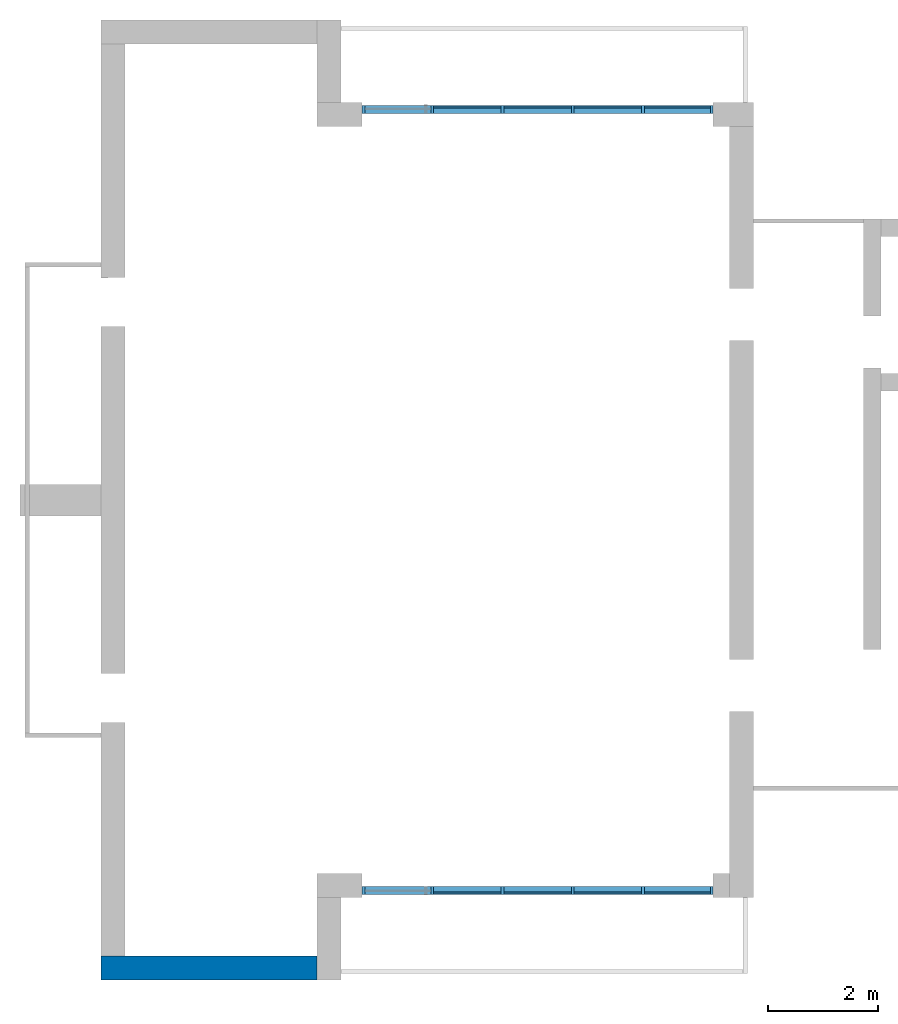
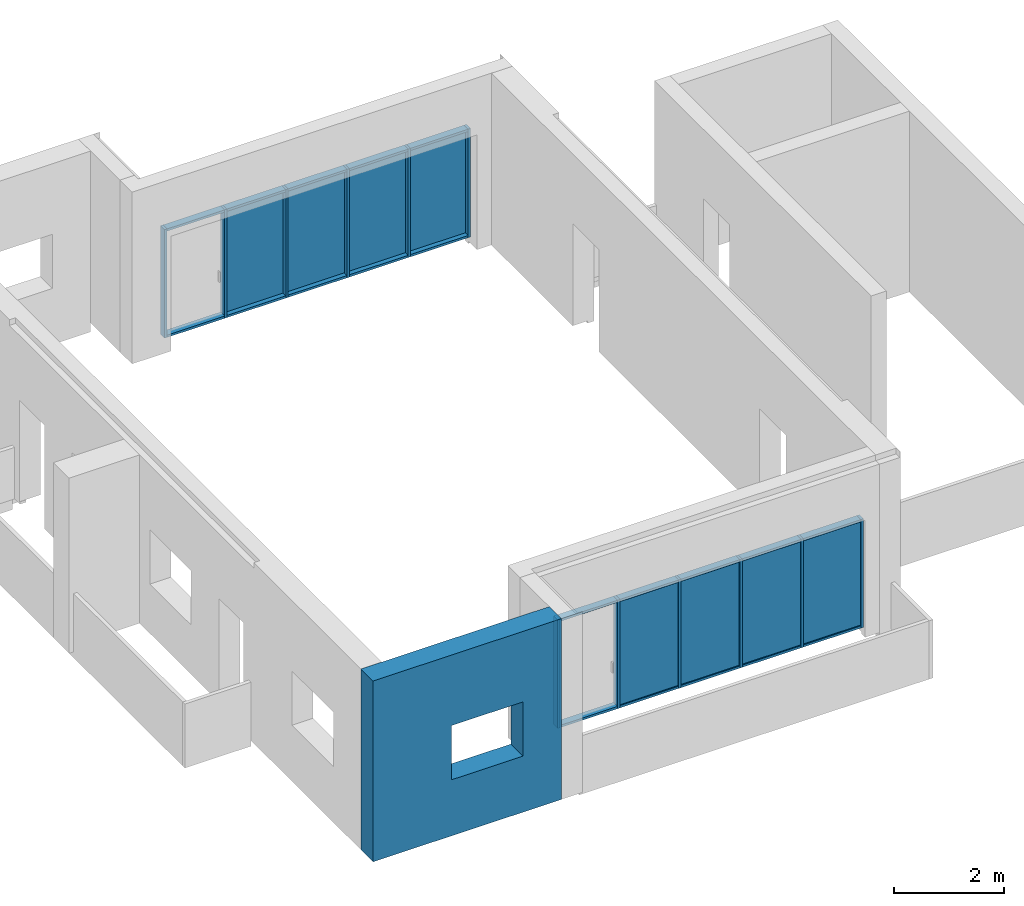
# One storey, part 1 of 4: 32 members, 8 plates, 1 wall, 1 opening, 2 elements without a shape of their own.
"""IFC2X3 building model written with IfcOpenShell, lengths in millimetres."""

from ifc_helpers import new_model, entity, si_unit, converted_unit, derived_unit, direction, frame, frame_2d, origin, origin_2d_with_axis, place, context, subcontext, project, spatial, rectangle, extrude, source, transform, mapped, material, layer, layer_set, layer_usage, type_object, type_shapes, element, aggregate, save


model = new_model("IFC2X3")

# Units and contexts
model_context = context("Model", 3, precision=0.01, world=origin(), true_north=direction((6.12303176911189e-17, 1.0)))
body_context = subcontext(model_context, "Body", "Model", "MODEL_VIEW")
ifc_project = project(units=[si_unit("LENGTHUNIT", "METRE", prefix="MILLI"), si_unit("AREAUNIT", "SQUARE_METRE"), si_unit("VOLUMEUNIT", "CUBIC_METRE"), converted_unit("PLANEANGLEUNIT", "DEGREE", entity("IfcRatioMeasure", 0.0174532925199433), si_unit("PLANEANGLEUNIT", "RADIAN"), dimensions=[0, 0, 0, 0, 0, 0, 0]), si_unit("MASSUNIT", "GRAM", prefix="KILO"), derived_unit("MASSDENSITYUNIT", [(si_unit("MASSUNIT", "GRAM", prefix="KILO"), 1), (si_unit("LENGTHUNIT", "METRE"), -3)]), si_unit("TIMEUNIT", "SECOND"), si_unit("FREQUENCYUNIT", "HERTZ"), si_unit("THERMODYNAMICTEMPERATUREUNIT", "DEGREE_CELSIUS"), derived_unit("THERMALTRANSMITTANCEUNIT", [(si_unit("MASSUNIT", "GRAM", prefix="KILO"), 1), (si_unit("THERMODYNAMICTEMPERATUREUNIT", "KELVIN"), -1), (si_unit("TIMEUNIT", "SECOND"), -3)]), derived_unit("VOLUMETRICFLOWRATEUNIT", [(si_unit("LENGTHUNIT", "METRE"), 3), (si_unit("TIMEUNIT", "SECOND"), -1)]), si_unit("ELECTRICCURRENTUNIT", "AMPERE"), si_unit("ELECTRICVOLTAGEUNIT", "VOLT"), si_unit("POWERUNIT", "WATT"), si_unit("FORCEUNIT", "NEWTON", prefix="KILO"), si_unit("ILLUMINANCEUNIT", "LUX"), si_unit("LUMINOUSFLUXUNIT", "LUMEN"), si_unit("LUMINOUSINTENSITYUNIT", "CANDELA"), derived_unit("USERDEFINED", [(si_unit("MASSUNIT", "GRAM", prefix="KILO"), -1), (si_unit("LENGTHUNIT", "METRE"), -2), (si_unit("TIMEUNIT", "SECOND"), 3), (si_unit("LUMINOUSFLUXUNIT", "LUMEN"), 1)]), derived_unit("LINEARVELOCITYUNIT", [(si_unit("LENGTHUNIT", "METRE"), 1), (si_unit("TIMEUNIT", "SECOND"), -1)]), si_unit("PRESSUREUNIT", "PASCAL"), derived_unit("USERDEFINED", [(si_unit("LENGTHUNIT", "METRE"), -2), (si_unit("MASSUNIT", "GRAM", prefix="KILO"), 1), (si_unit("TIMEUNIT", "SECOND"), -2)])], contexts=[model_context])

# Site, building, storey
site_placement = place(None, origin())
site = spatial("IfcSite", under=ifc_project, at=site_placement, CompositionType="ELEMENT")
building_placement = place(site_placement, origin())
building = spatial("IfcBuilding", under=site, at=building_placement, CompositionType="ELEMENT")
storey_placement = place(building_placement, frame((0.0, 0.0, 12000.0)))
storey = spatial("IfcBuildingStorey", under=building, at=storey_placement, Name="03 Level", CompositionType="ELEMENT", Elevation=12000.0)

# Curtain wall, members
curtain_wall_type = type_object("IfcCurtainWallType", Name="Curtain Wall", PredefinedType="NOTDEFINED")
curtain_wall_1_placement = place(storey_placement, frame((0.0, 0.0, -12000.0)))
curtain_wall_1 = element("IfcCurtainWall", 1, at=curtain_wall_1_placement, inside=storey, type_object=curtain_wall_type, Name="Curtain Wall", ObjectType="Curtain Wall")
ifc_material_1 = material(Name="Aluminium")
member_type_1 = type_object("IfcMemberType", Name="50 x 150mm", PredefinedType="MEMBER")
shared_shape_1 = source(origin(), body_context, "Body", "SweptSolid", [
    extrude(rectangle(XDim=150.0, YDim=50.0, at=origin_2d_with_axis()), frame((-25.0, 0.0, -2400.0), z_axis=(0.0, 0.0, 1.0), x_axis=(0.0, -1.0, 0.0)), (0.0, 0.0, 1.0), 2400.0),
])
type_shapes(member_type_1, [shared_shape_1])
member_1_placement = place(storey_placement, frame((21803.4900708518, -75951.2395851399, 0.0), z_axis=(0.0, 0.0, -1.0), x_axis=(-1.0, 0.0, 0.0)))
member_1 = element("IfcMember", 2, at=member_1_placement, type_object=member_type_1, material=ifc_material_1, Name="Rectangular Mullion:50 x 150mm", ObjectType="Rectangular Mullion:50 x 150mm", context=body_context, shape_type="MappedRepresentation", body=[
    mapped(shared_shape_1, transform((0.0, 0.0, 0.0), scale=1.0)),
])
member_type_2 = type_object("IfcMemberType", Name="50 x 150mm", PredefinedType="MEMBER")
shared_shape_2 = source(origin(), body_context, "Body", "SweptSolid", [
    extrude(rectangle(XDim=150.0, YDim=50.0, at=origin_2d_with_axis()), frame((0.0, 0.0, -2400.0), z_axis=(0.0, 0.0, 1.0), x_axis=(0.0, -1.0, 0.0)), (0.0, 0.0, 1.0), 2400.0),
])
type_shapes(member_type_2, [shared_shape_2])
member_2_placement = place(storey_placement, frame((23083.4900708518, -75951.2395851399, 0.0), z_axis=(0.0, 0.0, -1.0), x_axis=(-1.0, 0.0, 0.0)))
member_2 = element("IfcMember", 3, at=member_2_placement, type_object=member_type_2, material=ifc_material_1, Name="Rectangular Mullion:50 x 150mm", ObjectType="Rectangular Mullion:50 x 150mm", context=body_context, shape_type="MappedRepresentation", body=[
    mapped(shared_shape_2, transform((0.0, 0.0, 0.0), scale=1.0)),
])
member_3_placement = place(storey_placement, frame((24363.4900708518, -75951.2395851399, 0.0), z_axis=(0.0, 0.0, -1.0), x_axis=(-1.0, 0.0, 0.0)))
member_3 = element("IfcMember", 4, at=member_3_placement, type_object=member_type_2, material=ifc_material_1, Name="Rectangular Mullion:50 x 150mm", ObjectType="Rectangular Mullion:50 x 150mm", context=body_context, shape_type="MappedRepresentation", body=[
    mapped(shared_shape_2, transform((0.0, 0.0, 0.0), scale=1.0)),
])
member_4_placement = place(storey_placement, frame((25643.4900708518, -75951.2395851399, 0.0), z_axis=(0.0, 0.0, -1.0), x_axis=(-1.0, 0.0, 0.0)))
member_4 = element("IfcMember", 5, at=member_4_placement, type_object=member_type_2, material=ifc_material_1, Name="Rectangular Mullion:50 x 150mm", ObjectType="Rectangular Mullion:50 x 150mm", context=body_context, shape_type="MappedRepresentation", body=[
    mapped(shared_shape_2, transform((0.0, 0.0, 0.0), scale=1.0)),
])
member_5_placement = place(storey_placement, frame((26923.4900708518, -75951.2395851399, 0.0), z_axis=(0.0, 0.0, -1.0), x_axis=(-1.0, 0.0, 0.0)))
member_5 = element("IfcMember", 6, at=member_5_placement, type_object=member_type_2, material=ifc_material_1, Name="Rectangular Mullion:50 x 150mm", ObjectType="Rectangular Mullion:50 x 150mm", context=body_context, shape_type="MappedRepresentation", body=[
    mapped(shared_shape_2, transform((0.0, 0.0, 0.0), scale=1.0)),
])
member_type_3 = type_object("IfcMemberType", Name="50 x 150mm", PredefinedType="MEMBER")
shared_shape_3 = source(origin(), body_context, "Body", "SweptSolid", [
    extrude(rectangle(XDim=150.0, YDim=50.0, at=origin_2d_with_axis()), frame((-25.0, 0.0, -2400.0), z_axis=(0.0, 0.0, 1.0), x_axis=(0.0, -1.0, 0.0)), (0.0, 0.0, 1.0), 2400.0),
])
type_shapes(member_type_3, [shared_shape_3])
member_6_placement = place(storey_placement, frame((28203.4900708518, -75951.2395851399, 2400.0)))
member_6 = element("IfcMember", 7, at=member_6_placement, type_object=member_type_3, material=ifc_material_1, Name="Rectangular Mullion:50 x 150mm", ObjectType="Rectangular Mullion:50 x 150mm", context=body_context, shape_type="MappedRepresentation", body=[
    mapped(shared_shape_3, transform((0.0, 0.0, 0.0), scale=1.0)),
])
member_type_4 = type_object("IfcMemberType", Name="50 x 150mm", PredefinedType="MEMBER")
shared_shape_4 = source(origin(), body_context, "Body", "SweptSolid", [
    extrude(rectangle(XDim=150.0, YDim=50.0, at=origin_2d_with_axis()), frame((-25.0, 0.0, -1205.0), z_axis=(0.0, 0.0, 1.0), x_axis=(0.0, -1.0, 0.0)), (0.0, 0.0, 1.0), 1205.0),
])
type_shapes(member_type_4, [shared_shape_4])
member_7_placement = place(storey_placement, frame((26948.4900708518, -75951.2395851399, 2400.0), z_axis=(-1.0, 0.0, 0.0), x_axis=(0.0, 0.0, 1.0)))
member_7 = element("IfcMember", 8, at=member_7_placement, type_object=member_type_4, material=ifc_material_1, Name="Rectangular Mullion:50 x 150mm", ObjectType="Rectangular Mullion:50 x 150mm", context=body_context, shape_type="MappedRepresentation", body=[
    mapped(shared_shape_4, transform((0.0, 0.0, 0.0), scale=1.0)),
])
member_8_placement = place(storey_placement, frame((21853.4900708518, -75951.2395851399, 2400.0), z_axis=(-1.0, 0.0, 0.0), x_axis=(0.0, 0.0, 1.0)))
member_8 = element("IfcMember", 9, at=member_8_placement, type_object=member_type_4, material=ifc_material_1, Name="Rectangular Mullion:50 x 150mm", ObjectType="Rectangular Mullion:50 x 150mm", context=body_context, shape_type="MappedRepresentation", body=[
    mapped(shared_shape_4, transform((0.0, 0.0, 0.0), scale=1.0)),
])
member_type_5 = type_object("IfcMemberType", Name="50 x 150mm", PredefinedType="MEMBER")
shared_shape_5 = source(origin(), body_context, "Body", "SweptSolid", [
    extrude(rectangle(XDim=150.0, YDim=50.0, at=origin_2d_with_axis()), frame((-25.0, 0.0, -1230.0), z_axis=(0.0, 0.0, 1.0), x_axis=(0.0, -1.0, 0.0)), (0.0, 0.0, 1.0), 1230.0),
])
type_shapes(member_type_5, [shared_shape_5])
member_9_placement = place(storey_placement, frame((24388.4900708518, -75951.2395851399, 2400.0), z_axis=(-1.0, 0.0, 0.0), x_axis=(0.0, 0.0, 1.0)))
member_9 = element("IfcMember", 10, at=member_9_placement, type_object=member_type_5, material=ifc_material_1, Name="Rectangular Mullion:50 x 150mm", ObjectType="Rectangular Mullion:50 x 150mm", context=body_context, shape_type="MappedRepresentation", body=[
    mapped(shared_shape_5, transform((0.0, 0.0, 0.0), scale=1.0)),
])
member_10_placement = place(storey_placement, frame((25668.4900708518, -75951.2395851399, 2400.0), z_axis=(-1.0, 0.0, 0.0), x_axis=(0.0, 0.0, 1.0)))
member_10 = element("IfcMember", 11, at=member_10_placement, type_object=member_type_5, material=ifc_material_1, Name="Rectangular Mullion:50 x 150mm", ObjectType="Rectangular Mullion:50 x 150mm", context=body_context, shape_type="MappedRepresentation", body=[
    mapped(shared_shape_5, transform((0.0, 0.0, 0.0), scale=1.0)),
])
member_11_placement = place(storey_placement, frame((23108.4900708518, -75951.2395851399, 2400.0), z_axis=(-1.0, 0.0, 0.0), x_axis=(0.0, 0.0, 1.0)))
member_11 = element("IfcMember", 12, at=member_11_placement, type_object=member_type_5, material=ifc_material_1, Name="Rectangular Mullion:50 x 150mm", ObjectType="Rectangular Mullion:50 x 150mm", context=body_context, shape_type="MappedRepresentation", body=[
    mapped(shared_shape_5, transform((0.0, 0.0, 0.0), scale=1.0)),
])
member_type_6 = type_object("IfcMemberType", Name="50 x 150mm", PredefinedType="MEMBER")
shared_shape_6 = source(origin(), body_context, "Body", "SweptSolid", [
    extrude(rectangle(XDim=150.0, YDim=50.0, at=origin_2d_with_axis()), frame((-25.0, 0.0, -1230.0), z_axis=(0.0, 0.0, 1.0), x_axis=(0.0, -1.0, 0.0)), (0.0, 0.0, 1.0), 1230.0),
])
type_shapes(member_type_6, [shared_shape_6])
member_12_placement = place(storey_placement, frame((26898.4900708518, -75951.2395851399, 0.0), z_axis=(1.0, 0.0, 0.0), x_axis=(0.0, 0.0, -1.0)))
member_12 = element("IfcMember", 13, at=member_12_placement, type_object=member_type_6, material=ifc_material_1, Name="Rectangular Mullion:50 x 150mm", ObjectType="Rectangular Mullion:50 x 150mm", context=body_context, shape_type="MappedRepresentation", body=[
    mapped(shared_shape_6, transform((0.0, 0.0, 0.0), scale=1.0)),
])
member_13_placement = place(storey_placement, frame((24338.4900708518, -75951.2395851399, 0.0), z_axis=(1.0, 0.0, 0.0), x_axis=(0.0, 0.0, -1.0)))
member_13 = element("IfcMember", 14, at=member_13_placement, type_object=member_type_6, material=ifc_material_1, Name="Rectangular Mullion:50 x 150mm", ObjectType="Rectangular Mullion:50 x 150mm", context=body_context, shape_type="MappedRepresentation", body=[
    mapped(shared_shape_6, transform((0.0, 0.0, 0.0), scale=1.0)),
])
member_14_placement = place(storey_placement, frame((25618.4900708518, -75951.2395851399, 0.0), z_axis=(1.0, 0.0, 0.0), x_axis=(0.0, 0.0, -1.0)))
member_14 = element("IfcMember", 15, at=member_14_placement, type_object=member_type_6, material=ifc_material_1, Name="Rectangular Mullion:50 x 150mm", ObjectType="Rectangular Mullion:50 x 150mm", context=body_context, shape_type="MappedRepresentation", body=[
    mapped(shared_shape_6, transform((0.0, 0.0, 0.0), scale=1.0)),
])
member_type_7 = type_object("IfcMemberType", Name="50 x 150mm", PredefinedType="MEMBER")
shared_shape_7 = source(origin(), body_context, "Body", "SweptSolid", [
    extrude(rectangle(XDim=150.0, YDim=50.0, at=origin_2d_with_axis()), frame((-25.0, 0.0, -1205.0), z_axis=(0.0, 0.0, 1.0), x_axis=(0.0, -1.0, 0.0)), (0.0, 0.0, 1.0), 1205.0),
])
type_shapes(member_type_7, [shared_shape_7])
member_15_placement = place(storey_placement, frame((23058.4900708518, -75951.2395851399, 0.0), z_axis=(1.0, 0.0, 0.0), x_axis=(0.0, 0.0, -1.0)))
member_15 = element("IfcMember", 16, at=member_15_placement, type_object=member_type_7, material=ifc_material_1, Name="Rectangular Mullion:50 x 150mm", ObjectType="Rectangular Mullion:50 x 150mm", context=body_context, shape_type="MappedRepresentation", body=[
    mapped(shared_shape_7, transform((0.0, 0.0, 0.0), scale=1.0)),
])
member_16_placement = place(storey_placement, frame((28153.4900708518, -75951.2395851399, 0.0), z_axis=(1.0, 0.0, 0.0), x_axis=(0.0, 0.0, -1.0)))
member_16 = element("IfcMember", 17, at=member_16_placement, type_object=member_type_7, material=ifc_material_1, Name="Rectangular Mullion:50 x 150mm", ObjectType="Rectangular Mullion:50 x 150mm", context=body_context, shape_type="MappedRepresentation", body=[
    mapped(shared_shape_7, transform((0.0, 0.0, 0.0), scale=1.0)),
])

curtain_wall_2_placement = place(storey_placement, frame((0.0, 0.0, -12000.0)))
curtain_wall_2 = element("IfcCurtainWall", 18, at=curtain_wall_2_placement, inside=storey, type_object=curtain_wall_type, Name="Curtain Wall", ObjectType="Curtain Wall")
member_type_8 = type_object("IfcMemberType", Name="50 x 150mm", PredefinedType="MEMBER")
shared_shape_8 = source(origin(), body_context, "Body", "SweptSolid", [
    extrude(rectangle(XDim=150.0, YDim=50.0, at=origin_2d_with_axis()), frame((-25.0, 0.0, -2400.0), z_axis=(0.0, 0.0, 1.0), x_axis=(0.0, -1.0, 0.0)), (0.0, 0.0, 1.0), 2400.0),
])
type_shapes(member_type_8, [shared_shape_8])
member_17_placement = place(storey_placement, frame((21803.4900708518, -61711.23958514, 0.0), z_axis=(0.0, 0.0, -1.0), x_axis=(-1.0, 0.0, 0.0)))
member_17 = element("IfcMember", 19, at=member_17_placement, type_object=member_type_8, material=ifc_material_1, Name="Rectangular Mullion:50 x 150mm", ObjectType="Rectangular Mullion:50 x 150mm", context=body_context, shape_type="MappedRepresentation", body=[
    mapped(shared_shape_8, transform((0.0, 0.0, 0.0), scale=1.0)),
])
member_type_9 = type_object("IfcMemberType", Name="50 x 150mm", PredefinedType="MEMBER")
shared_shape_9 = source(origin(), body_context, "Body", "SweptSolid", [
    extrude(rectangle(XDim=150.0, YDim=50.0, at=origin_2d_with_axis()), frame((0.0, 0.0, -2400.0), z_axis=(0.0, 0.0, 1.0), x_axis=(0.0, -1.0, 0.0)), (0.0, 0.0, 1.0), 2400.0),
])
type_shapes(member_type_9, [shared_shape_9])
member_18_placement = place(storey_placement, frame((23083.4900708518, -61711.23958514, 0.0), z_axis=(0.0, 0.0, -1.0), x_axis=(-1.0, 0.0, 0.0)))
member_18 = element("IfcMember", 20, at=member_18_placement, type_object=member_type_9, material=ifc_material_1, Name="Rectangular Mullion:50 x 150mm", ObjectType="Rectangular Mullion:50 x 150mm", context=body_context, shape_type="MappedRepresentation", body=[
    mapped(shared_shape_9, transform((0.0, 0.0, 0.0), scale=1.0)),
])
member_19_placement = place(storey_placement, frame((24363.4900708518, -61711.23958514, 0.0), z_axis=(0.0, 0.0, -1.0), x_axis=(-1.0, 0.0, 0.0)))
member_19 = element("IfcMember", 21, at=member_19_placement, type_object=member_type_9, material=ifc_material_1, Name="Rectangular Mullion:50 x 150mm", ObjectType="Rectangular Mullion:50 x 150mm", context=body_context, shape_type="MappedRepresentation", body=[
    mapped(shared_shape_9, transform((0.0, 0.0, 0.0), scale=1.0)),
])
member_20_placement = place(storey_placement, frame((25643.4900708518, -61711.23958514, 0.0), z_axis=(0.0, 0.0, -1.0), x_axis=(-1.0, 0.0, 0.0)))
member_20 = element("IfcMember", 22, at=member_20_placement, type_object=member_type_9, material=ifc_material_1, Name="Rectangular Mullion:50 x 150mm", ObjectType="Rectangular Mullion:50 x 150mm", context=body_context, shape_type="MappedRepresentation", body=[
    mapped(shared_shape_9, transform((0.0, 0.0, 0.0), scale=1.0)),
])
member_21_placement = place(storey_placement, frame((26923.4900708518, -61711.23958514, 0.0), z_axis=(0.0, 0.0, -1.0), x_axis=(-1.0, 0.0, 0.0)))
member_21 = element("IfcMember", 23, at=member_21_placement, type_object=member_type_9, material=ifc_material_1, Name="Rectangular Mullion:50 x 150mm", ObjectType="Rectangular Mullion:50 x 150mm", context=body_context, shape_type="MappedRepresentation", body=[
    mapped(shared_shape_9, transform((0.0, 0.0, 0.0), scale=1.0)),
])
member_type_10 = type_object("IfcMemberType", Name="50 x 150mm", PredefinedType="MEMBER")
shared_shape_10 = source(origin(), body_context, "Body", "SweptSolid", [
    extrude(rectangle(XDim=150.0, YDim=50.0, at=origin_2d_with_axis()), frame((-25.0, 0.0, -2400.0), z_axis=(0.0, 0.0, 1.0), x_axis=(0.0, -1.0, 0.0)), (0.0, 0.0, 1.0), 2400.0),
])
type_shapes(member_type_10, [shared_shape_10])
member_22_placement = place(storey_placement, frame((28203.4900708519, -61711.23958514, 2400.0)))
member_22 = element("IfcMember", 24, at=member_22_placement, type_object=member_type_10, material=ifc_material_1, Name="Rectangular Mullion:50 x 150mm", ObjectType="Rectangular Mullion:50 x 150mm", context=body_context, shape_type="MappedRepresentation", body=[
    mapped(shared_shape_10, transform((0.0, 0.0, 0.0), scale=1.0)),
])
member_type_11 = type_object("IfcMemberType", Name="50 x 150mm", PredefinedType="MEMBER")
shared_shape_11 = source(origin(), body_context, "Body", "SweptSolid", [
    extrude(rectangle(XDim=150.0, YDim=50.0, at=origin_2d_with_axis()), frame((-25.0, 0.0, -1205.0), z_axis=(0.0, 0.0, 1.0), x_axis=(0.0, -1.0, 0.0)), (0.0, 0.0, 1.0), 1205.0),
])
type_shapes(member_type_11, [shared_shape_11])
member_23_placement = place(storey_placement, frame((26948.4900708518, -61711.23958514, 2400.0), z_axis=(-1.0, 0.0, 0.0), x_axis=(0.0, 0.0, 1.0)))
member_23 = element("IfcMember", 25, at=member_23_placement, type_object=member_type_11, material=ifc_material_1, Name="Rectangular Mullion:50 x 150mm", ObjectType="Rectangular Mullion:50 x 150mm", context=body_context, shape_type="MappedRepresentation", body=[
    mapped(shared_shape_11, transform((0.0, 0.0, 0.0), scale=1.0)),
])
member_24_placement = place(storey_placement, frame((21853.4900708518, -61711.23958514, 2400.0), z_axis=(-1.0, 0.0, 0.0), x_axis=(0.0, 0.0, 1.0)))
member_24 = element("IfcMember", 26, at=member_24_placement, type_object=member_type_11, material=ifc_material_1, Name="Rectangular Mullion:50 x 150mm", ObjectType="Rectangular Mullion:50 x 150mm", context=body_context, shape_type="MappedRepresentation", body=[
    mapped(shared_shape_11, transform((0.0, 0.0, 0.0), scale=1.0)),
])
member_type_12 = type_object("IfcMemberType", Name="50 x 150mm", PredefinedType="MEMBER")
shared_shape_12 = source(origin(), body_context, "Body", "SweptSolid", [
    extrude(rectangle(XDim=150.0, YDim=50.0, at=origin_2d_with_axis()), frame((-25.0, 0.0, -1230.0), z_axis=(0.0, 0.0, 1.0), x_axis=(0.0, -1.0, 0.0)), (0.0, 0.0, 1.0), 1230.0),
])
type_shapes(member_type_12, [shared_shape_12])
member_25_placement = place(storey_placement, frame((24388.4900708518, -61711.23958514, 2400.0), z_axis=(-1.0, 0.0, 0.0), x_axis=(0.0, 0.0, 1.0)))
member_25 = element("IfcMember", 27, at=member_25_placement, type_object=member_type_12, material=ifc_material_1, Name="Rectangular Mullion:50 x 150mm", ObjectType="Rectangular Mullion:50 x 150mm", context=body_context, shape_type="MappedRepresentation", body=[
    mapped(shared_shape_12, transform((0.0, 0.0, 0.0), scale=1.0)),
])
member_26_placement = place(storey_placement, frame((25668.4900708518, -61711.23958514, 2400.0), z_axis=(-1.0, 0.0, 0.0), x_axis=(0.0, 0.0, 1.0)))
member_26 = element("IfcMember", 28, at=member_26_placement, type_object=member_type_12, material=ifc_material_1, Name="Rectangular Mullion:50 x 150mm", ObjectType="Rectangular Mullion:50 x 150mm", context=body_context, shape_type="MappedRepresentation", body=[
    mapped(shared_shape_12, transform((0.0, 0.0, 0.0), scale=1.0)),
])
member_27_placement = place(storey_placement, frame((23108.4900708518, -61711.23958514, 2400.0), z_axis=(-1.0, 0.0, 0.0), x_axis=(0.0, 0.0, 1.0)))
member_27 = element("IfcMember", 29, at=member_27_placement, type_object=member_type_12, material=ifc_material_1, Name="Rectangular Mullion:50 x 150mm", ObjectType="Rectangular Mullion:50 x 150mm", context=body_context, shape_type="MappedRepresentation", body=[
    mapped(shared_shape_12, transform((0.0, 0.0, 0.0), scale=1.0)),
])
member_type_13 = type_object("IfcMemberType", Name="50 x 150mm", PredefinedType="MEMBER")
shared_shape_13 = source(origin(), body_context, "Body", "SweptSolid", [
    extrude(rectangle(XDim=150.0, YDim=50.0, at=origin_2d_with_axis()), frame((-25.0, 0.0, -1230.0), z_axis=(0.0, 0.0, 1.0), x_axis=(0.0, -1.0, 0.0)), (0.0, 0.0, 1.0), 1230.0),
])
type_shapes(member_type_13, [shared_shape_13])
member_28_placement = place(storey_placement, frame((26898.4900708518, -61711.23958514, 0.0), z_axis=(1.0, 0.0, 0.0), x_axis=(0.0, 0.0, -1.0)))
member_28 = element("IfcMember", 30, at=member_28_placement, type_object=member_type_13, material=ifc_material_1, Name="Rectangular Mullion:50 x 150mm", ObjectType="Rectangular Mullion:50 x 150mm", context=body_context, shape_type="MappedRepresentation", body=[
    mapped(shared_shape_13, transform((0.0, 0.0, 0.0), scale=1.0)),
])
member_29_placement = place(storey_placement, frame((24338.4900708518, -61711.23958514, 0.0), z_axis=(1.0, 0.0, 0.0), x_axis=(0.0, 0.0, -1.0)))
member_29 = element("IfcMember", 31, at=member_29_placement, type_object=member_type_13, material=ifc_material_1, Name="Rectangular Mullion:50 x 150mm", ObjectType="Rectangular Mullion:50 x 150mm", context=body_context, shape_type="MappedRepresentation", body=[
    mapped(shared_shape_13, transform((0.0, 0.0, 0.0), scale=1.0)),
])
member_30_placement = place(storey_placement, frame((25618.4900708519, -61711.23958514, 0.0), z_axis=(1.0, 0.0, 0.0), x_axis=(0.0, 0.0, -1.0)))
member_30 = element("IfcMember", 32, at=member_30_placement, type_object=member_type_13, material=ifc_material_1, Name="Rectangular Mullion:50 x 150mm", ObjectType="Rectangular Mullion:50 x 150mm", context=body_context, shape_type="MappedRepresentation", body=[
    mapped(shared_shape_13, transform((0.0, 0.0, 0.0), scale=1.0)),
])
member_type_14 = type_object("IfcMemberType", Name="50 x 150mm", PredefinedType="MEMBER")
shared_shape_14 = source(origin(), body_context, "Body", "SweptSolid", [
    extrude(rectangle(XDim=150.0, YDim=50.0, at=origin_2d_with_axis()), frame((-25.0, 0.0, -1205.0), z_axis=(0.0, 0.0, 1.0), x_axis=(0.0, -1.0, 0.0)), (0.0, 0.0, 1.0), 1205.0),
])
type_shapes(member_type_14, [shared_shape_14])
member_31_placement = place(storey_placement, frame((23058.4900708518, -61711.23958514, 0.0), z_axis=(1.0, 0.0, 0.0), x_axis=(0.0, 0.0, -1.0)))
member_31 = element("IfcMember", 33, at=member_31_placement, type_object=member_type_14, material=ifc_material_1, Name="Rectangular Mullion:50 x 150mm", ObjectType="Rectangular Mullion:50 x 150mm", context=body_context, shape_type="MappedRepresentation", body=[
    mapped(shared_shape_14, transform((0.0, 0.0, 0.0), scale=1.0)),
])
member_32_placement = place(storey_placement, frame((28153.4900708518, -61711.23958514, 0.0), z_axis=(1.0, 0.0, 0.0), x_axis=(0.0, 0.0, -1.0)))
member_32 = element("IfcMember", 34, at=member_32_placement, type_object=member_type_14, material=ifc_material_1, Name="Rectangular Mullion:50 x 150mm", ObjectType="Rectangular Mullion:50 x 150mm", context=body_context, shape_type="MappedRepresentation", body=[
    mapped(shared_shape_14, transform((0.0, 0.0, 0.0), scale=1.0)),
])

# Plate
ifc_material_2 = material()
ifc_layer_1 = layer(ifc_material_2, 25.0)
ifc_layer_set_1 = layer_set([ifc_layer_1], Name="System Panel:Glazed")
ifc_layer_usage_1 = layer_usage(ifc_layer_set_1, "AXIS3", "POSITIVE", 0.121391076115486)
plate_type_1 = type_object("IfcPlateType", Name="Glazed", PredefinedType="CURTAIN_PANEL", material=ifc_layer_set_1)
shared_shape_15 = source(origin(), body_context, "Body", "SweptSolid", [
    extrude(rectangle(XDim=25.0, YDim=1205.0, at=origin_2d_with_axis()), frame((602.499999999999, 12.5, 0.0), z_axis=(0.0, 0.0, 1.0), x_axis=(0.0, 1.0, 0.0)), (0.0, 0.0, 1.0), 2300.0),
])
type_shapes(plate_type_1, [shared_shape_15])
plate_1_placement = place(curtain_wall_1_placement, frame((28153.4900708518, -75975.7395851399, 12050.0), z_axis=(0.0, 0.0, 1.0), x_axis=(-1.0, 0.0, 0.0)))
plate_1 = element("IfcPlate", 35, at=plate_1_placement, type_object=plate_type_1, material=ifc_layer_usage_1, Name="System Panel:Glazed", ObjectType="System Panel:Glazed", context=body_context, shape_type="MappedRepresentation", body=[
    mapped(shared_shape_15, transform((0.0, 0.0, 0.0), scale=1.0)),
])

ifc_layer_usage_2 = layer_usage(ifc_layer_set_1, "AXIS3", "POSITIVE", 0.121391076115486)
plate_type_2 = type_object("IfcPlateType", Name="Glazed", PredefinedType="CURTAIN_PANEL", material=ifc_layer_set_1)
shared_shape_16 = source(origin(), body_context, "Body", "SweptSolid", [
    extrude(rectangle(XDim=25.0, YDim=1230.00000000001, at=origin_2d_with_axis()), frame((615.0, 12.5, 0.0), z_axis=(0.0, 0.0, 1.0), x_axis=(0.0, 1.0, 0.0)), (0.0, 0.0, 1.0), 2300.0),
])
type_shapes(plate_type_2, [shared_shape_16])
plate_2_placement = place(curtain_wall_1_placement, frame((26898.4900708518, -75975.7395851399, 12050.0), z_axis=(0.0, 0.0, 1.0), x_axis=(-1.0, 0.0, 0.0)))
plate_2 = element("IfcPlate", 36, at=plate_2_placement, type_object=plate_type_2, material=ifc_layer_usage_2, Name="System Panel:Glazed", ObjectType="System Panel:Glazed", context=body_context, shape_type="MappedRepresentation", body=[
    mapped(shared_shape_16, transform((0.0, 0.0, 0.0), scale=1.0)),
])

ifc_layer_usage_3 = layer_usage(ifc_layer_set_1, "AXIS3", "POSITIVE", 0.121391076115486)
plate_3_placement = place(curtain_wall_1_placement, frame((25618.4900708518, -75975.7395851399, 12050.0), z_axis=(0.0, 0.0, 1.0), x_axis=(-1.0, 0.0, 0.0)))
plate_3 = element("IfcPlate", 37, at=plate_3_placement, type_object=plate_type_2, material=ifc_layer_usage_3, Name="System Panel:Glazed", ObjectType="System Panel:Glazed", context=body_context, shape_type="MappedRepresentation", body=[
    mapped(shared_shape_16, transform((0.0, 0.0, 0.0), scale=1.0)),
])

ifc_layer_usage_4 = layer_usage(ifc_layer_set_1, "AXIS3", "POSITIVE", 0.121391076115486)
plate_4_placement = place(curtain_wall_1_placement, frame((24338.4900708518, -75975.7395851399, 12050.0), z_axis=(0.0, 0.0, 1.0), x_axis=(-1.0, 0.0, 0.0)))
plate_4 = element("IfcPlate", 38, at=plate_4_placement, type_object=plate_type_2, material=ifc_layer_usage_4, Name="System Panel:Glazed", ObjectType="System Panel:Glazed", context=body_context, shape_type="MappedRepresentation", body=[
    mapped(shared_shape_16, transform((0.0, 0.0, 0.0), scale=1.0)),
])

aggregate(curtain_wall_1, [plate_1, plate_2, plate_3, plate_4, member_1, member_2, member_3, member_4, member_5, member_6, member_7, member_9, member_10, member_11, member_8, member_12, member_13, member_14, member_15, member_16])

ifc_layer_usage_5 = layer_usage(ifc_layer_set_1, "AXIS3", "POSITIVE", 0.121391076115486)
plate_type_3 = type_object("IfcPlateType", Name="Glazed", PredefinedType="CURTAIN_PANEL", material=ifc_layer_set_1)
shared_shape_17 = source(origin(), body_context, "Body", "SweptSolid", [
    extrude(rectangle(XDim=25.0, YDim=1205.0, at=frame_2d((2.66453525910038e-15, 0.0), x_axis=(1.0, 0.0))), frame((602.499999999999, 12.5, 0.0), z_axis=(0.0, 0.0, 1.0), x_axis=(0.0, 1.0, 0.0)), (0.0, 0.0, 1.0), 2300.0),
])
type_shapes(plate_type_3, [shared_shape_17])
plate_5_placement = place(curtain_wall_2_placement, frame((28153.4900708518, -61661.73958514, 12050.0), z_axis=(0.0, 0.0, 1.0), x_axis=(-1.0, 0.0, 0.0)))
plate_5 = element("IfcPlate", 39, at=plate_5_placement, type_object=plate_type_3, material=ifc_layer_usage_5, Name="System Panel:Glazed", ObjectType="System Panel:Glazed", context=body_context, shape_type="MappedRepresentation", body=[
    mapped(shared_shape_17, transform((0.0, 0.0, 0.0), scale=1.0)),
])

ifc_layer_usage_6 = layer_usage(ifc_layer_set_1, "AXIS3", "POSITIVE", 0.121391076115486)
plate_type_4 = type_object("IfcPlateType", Name="Glazed", PredefinedType="CURTAIN_PANEL", material=ifc_layer_set_1)
shared_shape_18 = source(origin(), body_context, "Body", "SweptSolid", [
    extrude(rectangle(XDim=25.0, YDim=1230.0, at=frame_2d((2.66453525910038e-15, 0.0), x_axis=(1.0, 0.0))), frame((615.0, 12.5, 0.0), z_axis=(0.0, 0.0, 1.0), x_axis=(0.0, 1.0, 0.0)), (0.0, 0.0, 1.0), 2300.0),
])
type_shapes(plate_type_4, [shared_shape_18])
plate_6_placement = place(curtain_wall_2_placement, frame((26898.4900708518, -61661.73958514, 12050.0), z_axis=(0.0, 0.0, 1.0), x_axis=(-1.0, 0.0, 0.0)))
plate_6 = element("IfcPlate", 40, at=plate_6_placement, type_object=plate_type_4, material=ifc_layer_usage_6, Name="System Panel:Glazed", ObjectType="System Panel:Glazed", context=body_context, shape_type="MappedRepresentation", body=[
    mapped(shared_shape_18, transform((0.0, 0.0, 0.0), scale=1.0)),
])

ifc_layer_usage_7 = layer_usage(ifc_layer_set_1, "AXIS3", "POSITIVE", 0.121391076115486)
plate_7_placement = place(curtain_wall_2_placement, frame((25618.4900708518, -61661.73958514, 12050.0), z_axis=(0.0, 0.0, 1.0), x_axis=(-1.0, 0.0, 0.0)))
plate_7 = element("IfcPlate", 41, at=plate_7_placement, type_object=plate_type_4, material=ifc_layer_usage_7, Name="System Panel:Glazed", ObjectType="System Panel:Glazed", context=body_context, shape_type="MappedRepresentation", body=[
    mapped(shared_shape_18, transform((0.0, 0.0, 0.0), scale=1.0)),
])

ifc_layer_usage_8 = layer_usage(ifc_layer_set_1, "AXIS3", "POSITIVE", 0.121391076115486)
plate_8_placement = place(curtain_wall_2_placement, frame((24338.4900708518, -61661.73958514, 12050.0), z_axis=(0.0, 0.0, 1.0), x_axis=(-1.0, 0.0, 0.0)))
plate_8 = element("IfcPlate", 42, at=plate_8_placement, type_object=plate_type_4, material=ifc_layer_usage_8, Name="System Panel:Glazed", ObjectType="System Panel:Glazed", context=body_context, shape_type="MappedRepresentation", body=[
    mapped(shared_shape_18, transform((0.0, 0.0, 0.0), scale=1.0)),
])

aggregate(curtain_wall_2, [plate_5, plate_6, plate_7, plate_8, member_17, member_18, member_19, member_20, member_21, member_22, member_23, member_25, member_26, member_27, member_24, member_28, member_29, member_30, member_31, member_32])

# Wall, opening
ifc_material_3 = material(Name="03")
ifc_layer_2 = layer(ifc_material_3, 10.0)
ifc_material_4 = material()
ifc_layer_3 = layer(ifc_material_4, 120.0)
ifc_material_5 = material()
ifc_layer_4 = layer(ifc_material_5, 300.0)
ifc_layer_5 = layer(ifc_material_3, 10.0)
ifc_layer_set_2 = layer_set([ifc_layer_2, ifc_layer_3, ifc_layer_4, ifc_layer_5], Name="Basic Wall:00_fal+12 cm")
ifc_layer_usage_9 = layer_usage(ifc_layer_set_2, "AXIS2", "NEGATIVE", 220.0)
wall_type = type_object("IfcWallType", Name="Basic Wall:00_fal+12 cm", PredefinedType="STANDARD", material=ifc_layer_set_2)
wall_placement = place(storey_placement, frame((20983.4900708518, -77361.2395851399, -340.0), z_axis=(0.0, 0.0, 1.0), x_axis=(-1.0, 0.0, 0.0)))
wall = element("IfcWallStandardCase", 43, at=wall_placement, inside=storey, type_object=wall_type, material=ifc_layer_usage_9, Name="Basic Wall:00_fal+12 cm", ObjectType="Basic Wall:00_fal+12 cm", context=body_context, shape_type="SweptSolid", body=[
    extrude(rectangle(XDim=3940.00000000002, YDim=440.000000000004, at=frame_2d((1970.00000000001, 0.0), x_axis=(-1.0, 0.0))), origin(), (0.0, 0.0, 1.0), 4000.0),
])
opening_placement = place(wall_placement, frame((2300.0, 1744.0, 1240.0), z_axis=(0.0, 0.0, 1.0), x_axis=(-1.0, 0.0, 0.0)))
element("IfcOpeningElement", 44, at=opening_placement, cuts=wall, Name="Basic Wall:00_fal+12 cm", ObjectType="Opening", context=body_context, shape_type="SweptSolid", body=[
    extrude(rectangle(XDim=1200.0, YDim=1500.0, at=frame_2d((-1.08002495835535e-12, 0.0), x_axis=(0.0, 1.0))), frame((750.0, 3048.0, 600.0), z_axis=(0.0, -1.0, 0.0), x_axis=(1.0, 0.0, 0.0)), (0.0, 0.0, 1.0), 3048.0),
])

save(model, "model.ifc")
